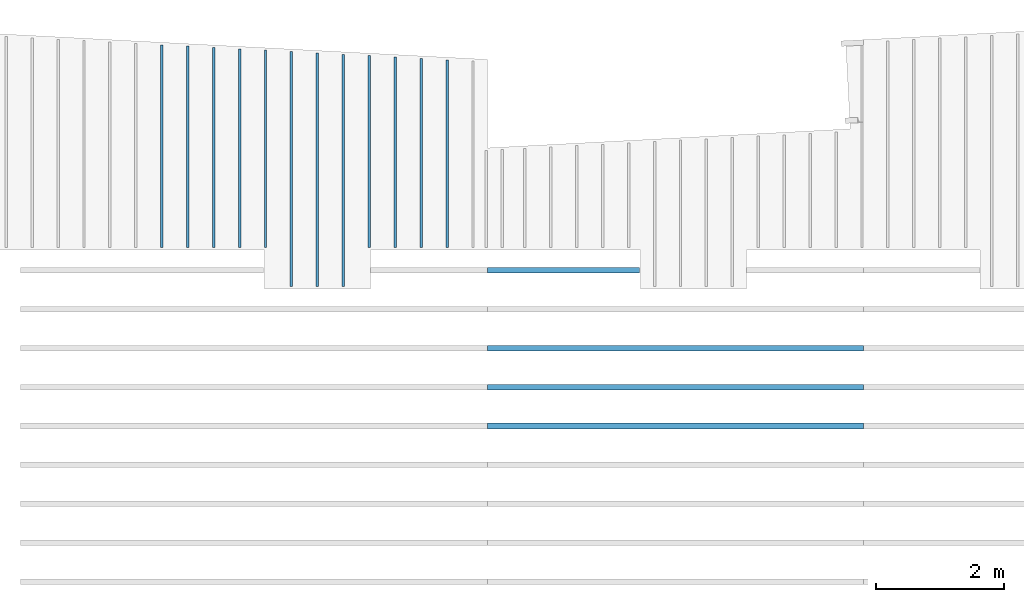
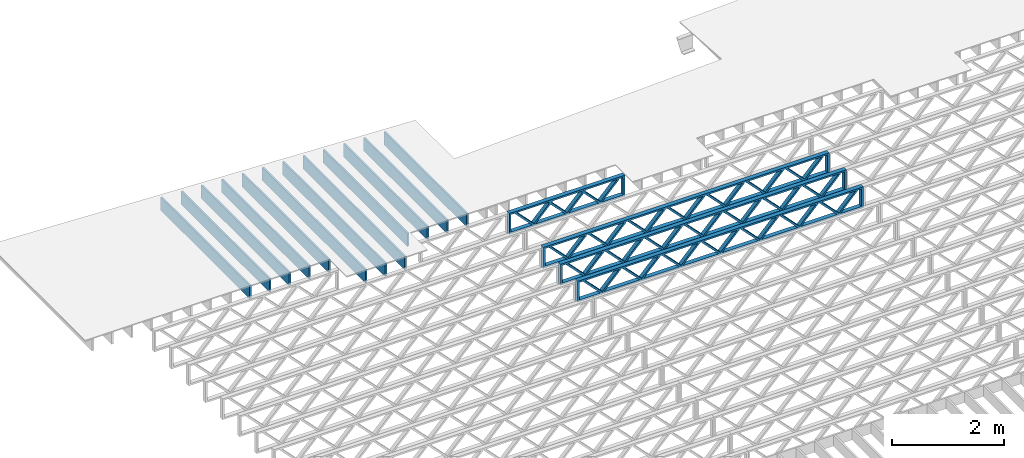
# One storey, part 4 of 13: 16 beams, 2 elements without a shape of their own.
"""IFC4 building model written with IfcOpenShell, lengths in feet."""

from ifc_helpers import new_model, entity, si_unit, converted_unit, derived_unit, direction, frame, frame_2d, origin, origin_2d_with_axis, place, context, subcontext, project, spatial, rectangle, extrude, source, transform, mapped, material, material_profile, profile_set, profile_usage, type_object, type_shapes, element, aggregate, save


model = new_model("IFC4")

# Units and contexts
model_context_1 = context("Model", 3, precision=0.0001, world=origin(), true_north=direction((6.12303176911189e-17, 1.0)))
model_context_2 = context("Model", 3, precision=0.0001, world=origin(), true_north=direction((6.12303176911189e-17, 1.0)))
body_context = subcontext(model_context_2, "Body", "Model", "MODEL_VIEW")
ifc_project = project(units=[converted_unit("LENGTHUNIT", "FOOT", entity("IfcRatioMeasure", 0.3048), si_unit("LENGTHUNIT", "METRE"), dimensions=[1, 0, 0, 0, 0, 0, 0]), converted_unit("AREAUNIT", "SQUARE FOOT", entity("IfcRatioMeasure", 0.09290304), si_unit("AREAUNIT", "SQUARE_METRE"), dimensions=[2, 0, 0, 0, 0, 0, 0]), converted_unit("VOLUMEUNIT", "CUBIC FOOT", entity("IfcRatioMeasure", 0.028316846592), si_unit("VOLUMEUNIT", "CUBIC_METRE"), dimensions=[3, 0, 0, 0, 0, 0, 0]), converted_unit("PLANEANGLEUNIT", "DEGREE", entity("IfcRatioMeasure", 0.0174532925199433), si_unit("PLANEANGLEUNIT", "RADIAN"), dimensions=[0, 0, 0, 0, 0, 0, 0]), si_unit("MASSUNIT", "GRAM", prefix="KILO"), derived_unit("MASSDENSITYUNIT", [(si_unit("MASSUNIT", "GRAM", prefix="KILO"), 1), (si_unit("LENGTHUNIT", "METRE"), -3)]), derived_unit("MOMENTOFINERTIAUNIT", [(si_unit("LENGTHUNIT", "METRE"), 4)]), si_unit("TIMEUNIT", "SECOND"), si_unit("FREQUENCYUNIT", "HERTZ"), si_unit("THERMODYNAMICTEMPERATUREUNIT", "DEGREE_CELSIUS"), derived_unit("THERMALTRANSMITTANCEUNIT", [(si_unit("MASSUNIT", "GRAM", prefix="KILO"), 1), (si_unit("THERMODYNAMICTEMPERATUREUNIT", "KELVIN"), -1), (si_unit("TIMEUNIT", "SECOND"), -3)]), derived_unit("VOLUMETRICFLOWRATEUNIT", [(si_unit("LENGTHUNIT", "METRE"), 3), (si_unit("TIMEUNIT", "SECOND"), -1)]), si_unit("ELECTRICCURRENTUNIT", "AMPERE"), si_unit("ELECTRICVOLTAGEUNIT", "VOLT"), si_unit("POWERUNIT", "WATT"), si_unit("FORCEUNIT", "NEWTON"), si_unit("ILLUMINANCEUNIT", "LUX"), si_unit("LUMINOUSFLUXUNIT", "LUMEN"), si_unit("LUMINOUSINTENSITYUNIT", "CANDELA"), derived_unit("USERDEFINED", [(si_unit("MASSUNIT", "GRAM", prefix="KILO"), -1), (si_unit("LENGTHUNIT", "METRE"), -2), (si_unit("TIMEUNIT", "SECOND"), 3), (si_unit("LUMINOUSFLUXUNIT", "LUMEN"), 1)]), derived_unit("LINEARVELOCITYUNIT", [(si_unit("LENGTHUNIT", "METRE"), 1), (si_unit("TIMEUNIT", "SECOND"), -1)]), si_unit("PRESSUREUNIT", "PASCAL"), derived_unit("USERDEFINED", [(si_unit("LENGTHUNIT", "METRE"), -2), (si_unit("MASSUNIT", "GRAM", prefix="KILO"), 1), (si_unit("TIMEUNIT", "SECOND"), -2)]), derived_unit("LINEARFORCEUNIT", [(si_unit("MASSUNIT", "GRAM", prefix="KILO"), 1), (si_unit("LENGTHUNIT", "METRE"), 1), (si_unit("TIMEUNIT", "SECOND"), -2), (si_unit("LENGTHUNIT", "METRE"), -1)]), derived_unit("PLANARFORCEUNIT", [(si_unit("MASSUNIT", "GRAM", prefix="KILO"), 1), (si_unit("LENGTHUNIT", "METRE"), 1), (si_unit("TIMEUNIT", "SECOND"), -2), (si_unit("LENGTHUNIT", "METRE"), -2)])], contexts=[model_context_1])

# Site, building, storey
site_placement = place(None, origin())
site = spatial("IfcSite", under=ifc_project, at=site_placement, CompositionType="ELEMENT")
building_placement = place(site_placement, origin())
building = spatial("IfcBuilding", under=site, at=building_placement, CompositionType="ELEMENT")
storey_placement = place(building_placement, frame((0.0, 0.0, 21.46875)))
storey = spatial("IfcBuildingStorey", under=building, at=storey_placement, Name="3RD FLOOR", CompositionType="ELEMENT", Elevation=21.46875)

# Assembly, beams
assembly_1_placement = place(storey_placement, origin())
assembly_1 = element("IfcElementAssembly", 1, at=assembly_1_placement, inside=storey, Name="Structural Beam System:Structural Framing System", ObjectType="Structural Beam System:Structural Framing System", AssemblyPlace="NOTDEFINED", PredefinedType="BEAM_GRID")
ifc_material_1 = material(Name="WOOD TRUSS", Category="Materials")
ifc_material_profile_1 = material_profile(ifc_material_1, rectangle(XDim=1.73473973950632, YDim=0.125, at=frame_2d((-1.11022302462516e-16, 8.32667268468867e-17), x_axis=(1.0, 0.0))))
ifc_material_profile_2 = material_profile(ifc_material_1, rectangle(XDim=1.73473973950633, YDim=0.125, at=frame_2d((-1.11022302462516e-16, 8.32667268468867e-17), x_axis=(1.0, 0.0))))
ifc_material_profile_3 = material_profile(ifc_material_1, rectangle(XDim=1.73473973950632, YDim=0.125, at=frame_2d((-5.55111512312578e-17, 1.38777878078145e-16), x_axis=(1.0, 0.0))))
ifc_material_profile_4 = material_profile(ifc_material_1, rectangle(XDim=1.73473973950633, YDim=0.125, at=frame_2d((-1.11022302462516e-16, 8.32667268468867e-17), x_axis=(1.0, 0.0))))
ifc_material_profile_5 = material_profile(ifc_material_1, rectangle(XDim=1.73473973950632, YDim=0.125, at=frame_2d((-1.11022302462516e-16, 8.32667268468867e-17), x_axis=(1.0, 0.0))))
ifc_material_profile_6 = material_profile(ifc_material_1, rectangle(XDim=1.73473973950633, YDim=0.125, at=frame_2d((-2.77555756156289e-16, 3.05311331771918e-16), x_axis=(1.0, 0.0))))
ifc_material_profile_7 = material_profile(ifc_material_1, rectangle(XDim=1.73473973950632, YDim=0.124999999999999, at=frame_2d((-3.88578058618805e-16, -2.4980018054066e-16), x_axis=(1.0, 0.0))))
ifc_material_profile_8 = material_profile(ifc_material_1, rectangle(XDim=1.73473973950633, YDim=0.125, at=frame_2d((2.77555756156289e-16, -3.05311331771918e-16), x_axis=(1.0, 0.0))))
ifc_material_profile_9 = material_profile(ifc_material_1, rectangle(XDim=1.73473973950632, YDim=0.124999999999999, at=frame_2d((-1.11022302462516e-16, 8.32667268468867e-17), x_axis=(1.0, 0.0))))
ifc_material_profile_10 = material_profile(ifc_material_1, rectangle(XDim=1.73473973950633, YDim=0.125, at=origin_2d_with_axis()))
ifc_material_profile_11 = material_profile(ifc_material_1, rectangle(XDim=0.124999999999982, YDim=0.291666666666668, at=origin_2d_with_axis()))
ifc_material_profile_12 = material_profile(ifc_material_1, rectangle(XDim=0.124999999999932, YDim=0.291666666666664, at=origin_2d_with_axis()))
ifc_material_profile_13 = material_profile(ifc_material_1, rectangle(XDim=1.25000000000002, YDim=0.29166666666667, at=origin_2d_with_axis()))
ifc_material_profile_14 = material_profile(ifc_material_1, rectangle(XDim=1.25000000000004, YDim=0.291666666666667, at=origin_2d_with_axis()))
ifc_profile_set_1 = profile_set([ifc_material_profile_1, ifc_material_profile_2, ifc_material_profile_3, ifc_material_profile_4, ifc_material_profile_5, ifc_material_profile_6, ifc_material_profile_7, ifc_material_profile_8, ifc_material_profile_9, ifc_material_profile_10, ifc_material_profile_11, ifc_material_profile_12, ifc_material_profile_13, ifc_material_profile_14])
ifc_profile_usage_1 = profile_usage(ifc_profile_set_1, cardinal=8)
beam_type_1 = type_object("IfcBeamType", PredefinedType="BEAM", material=ifc_profile_set_1)
shared_shape_1 = source(origin(), body_context, "Body", "SweptSolid", [
    extrude(rectangle(XDim=1.73473973950632, YDim=0.124999999999999, at=frame_2d((5.55111512312578e-16, 7.21644966006352e-16), x_axis=(1.0, 0.0))), frame((5.95847627016997, -0.145833333333334, 0.0), z_axis=(0.0, 1.0, 0.0), x_axis=(0.693383046997606, 0.0, 0.720569184836762)), (0.0, 0.0, 1.0), 0.291666666666667),
    extrude(rectangle(XDim=1.73473973950633, YDim=0.125, at=origin_2d_with_axis()), frame((4.7081903964967, -0.145833333333334, 0.0), z_axis=(0.0, 1.0, 0.0), x_axis=(0.69338304699761, 0.0, -0.720569184836758)), (0.0, 0.0, 1.0), 0.291666666666666),
    extrude(rectangle(XDim=1.73473973950632, YDim=0.125, at=frame_2d((2.22044604925031e-16, 3.88578058618805e-16), x_axis=(1.0, 0.0))), frame((3.29180960350347, -0.145833333333334, 0.0), z_axis=(0.0, 1.0, 0.0), x_axis=(0.693383046997606, 0.0, 0.720569184836762)), (0.0, 0.0, 1.0), 0.291666666666667),
    extrude(rectangle(XDim=1.73473973950633, YDim=0.125, at=frame_2d((1.11022302462516e-16, -8.32667268468867e-17), x_axis=(1.0, 0.0))), frame((2.0415237298302, -0.145833333333334, 0.0), z_axis=(0.0, 1.0, 0.0), x_axis=(0.69338304699761, 0.0, -0.720569184836758)), (0.0, 0.0, 1.0), 0.291666666666667),
    extrude(rectangle(XDim=1.73473973950632, YDim=0.125, at=frame_2d((-5.55111512312578e-17, 1.38777878078145e-16), x_axis=(1.0, 0.0))), frame((0.625142936836964, -0.145833333333334, 0.0), z_axis=(0.0, 1.0, 0.0), x_axis=(0.693383046997606, 0.0, 0.720569184836762)), (0.0, 0.0, 1.0), 0.291666666666667),
    extrude(rectangle(XDim=1.73473973950633, YDim=0.125, at=frame_2d((-1.11022302462516e-16, 8.32667268468867e-17), x_axis=(1.0, 0.0))), frame((-0.625142936836306, -0.145833333333334, 0.0), z_axis=(0.0, 1.0, 0.0), x_axis=(0.69338304699761, 0.0, -0.720569184836758)), (0.0, 0.0, 1.0), 0.291666666666667),
    extrude(rectangle(XDim=1.73473973950632, YDim=0.125, at=frame_2d((-1.11022302462516e-16, 8.32667268468867e-17), x_axis=(1.0, 0.0))), frame((-2.04152372982954, -0.145833333333334, 0.0), z_axis=(0.0, 1.0, 0.0), x_axis=(0.693383046997606, 0.0, 0.720569184836762)), (0.0, 0.0, 1.0), 0.291666666666667),
    extrude(rectangle(XDim=1.73473973950633, YDim=0.125, at=origin_2d_with_axis()), frame((-3.29180960350281, -0.145833333333334, 0.0), z_axis=(0.0, 1.0, 0.0), x_axis=(0.69338304699761, 0.0, -0.720569184836758)), (0.0, 0.0, 1.0), 0.291666666666667),
    extrude(rectangle(XDim=1.73473973950632, YDim=0.124999999999999, at=frame_2d((-1.11022302462516e-16, 8.32667268468867e-17), x_axis=(1.0, 0.0))), frame((-4.70819039649604, -0.145833333333334, 0.0), z_axis=(0.0, 1.0, 0.0), x_axis=(0.693383046997606, 0.0, 0.720569184836762)), (0.0, 0.0, 1.0), 0.291666666666667),
    extrude(rectangle(XDim=1.73473973950633, YDim=0.125, at=frame_2d((-5.55111512312578e-16, 6.38378239159465e-16), x_axis=(1.0, 0.0))), frame((-5.95847627016931, -0.145833333333334, 0.0), z_axis=(0.0, 1.0, 0.0), x_axis=(0.69338304699761, 0.0, -0.720569184836758)), (0.0, 0.0, 1.0), 0.291666666666666),
    extrude(rectangle(XDim=1.73473973950632, YDim=0.125, at=frame_2d((-7.21644966006352e-16, -5.82867087928207e-16), x_axis=(1.0, 0.0))), frame((8.62514293683647, -0.145833333333334, 0.0), z_axis=(0.0, 1.0, 0.0), x_axis=(0.693383046997607, 0.0, 0.720569184836761)), (0.0, 0.0, 1.0), 0.291666666666667),
    extrude(rectangle(XDim=1.73473973950633, YDim=0.125, at=origin_2d_with_axis()), frame((7.3748570631632, -0.145833333333334, 0.0), z_axis=(0.0, 1.0, 0.0), x_axis=(0.69338304699761, 0.0, -0.720569184836758)), (0.0, 0.0, 1.0), 0.291666666666666),
    extrude(rectangle(XDim=1.73473973950632, YDim=0.124999999999999, at=frame_2d((-1.11022302462516e-16, 8.32667268468867e-17), x_axis=(1.0, 0.0))), frame((-7.37485706316255, -0.145833333333334, 0.0), z_axis=(0.0, 1.0, 0.0), x_axis=(0.693383046997606, 0.0, 0.720569184836762)), (0.0, 0.0, 1.0), 0.291666666666667),
    extrude(rectangle(XDim=1.73473973950633, YDim=0.125, at=origin_2d_with_axis()), frame((-8.62514293683582, -0.145833333333334, 0.0), z_axis=(0.0, 1.0, 0.0), x_axis=(0.69338304699761, 0.0, -0.720569184836758)), (0.0, 0.0, 1.0), 0.291666666666666),
    extrude(rectangle(XDim=0.124999999999982, YDim=0.291666666666668, at=origin_2d_with_axis()), frame((-9.66666666666609, 0.0, 0.687500000000054), z_axis=(1.0, 0.0, 0.0), x_axis=(0.0, 0.0, -1.0)), (0.0, 0.0, 1.0), 19.3333333333322),
    extrude(rectangle(XDim=0.124999999999932, YDim=0.291666666666664, at=origin_2d_with_axis()), frame((-9.66666666666588, 0.0, -0.687499999999984), z_axis=(1.0, 0.0, 0.0), x_axis=(0.0, 0.0, -1.0)), (0.0, 0.0, 1.0), 19.333333333332),
    extrude(rectangle(XDim=1.25000000000002, YDim=0.29166666666667, at=origin_2d_with_axis()), frame((9.54166666666607, 0.0, 0.0), z_axis=(1.0, 0.0, 0.0), x_axis=(0.0, 0.0, -1.0)), (0.0, 0.0, 1.0), 0.12500000000002),
    extrude(rectangle(XDim=1.25000000000004, YDim=0.291666666666667, at=origin_2d_with_axis()), frame((-9.66666666666609, 0.0, 0.0), z_axis=(1.0, 0.0, 0.0), x_axis=(0.0, 0.0, -1.0)), (0.0, 0.0, 1.0), 0.125000000000023),
])
type_shapes(beam_type_1, [shared_shape_1])
beam_1_placement = place(assembly_1_placement, frame((-232.071493788724, 953.861934882651, -0.947916666666661)))
beam_1 = element("IfcBeam", 2, at=beam_1_placement, type_object=beam_type_1, material=ifc_profile_usage_1, PredefinedType="BEAM", context=body_context, shape_type="MappedRepresentation", body=[
    mapped(shared_shape_1, transform((0.0, 0.0, 0.0), scale=1.0)),
])
ifc_profile_usage_2 = profile_usage(ifc_profile_set_1, cardinal=8)
beam_2_placement = place(assembly_1_placement, frame((-232.071493788724, 951.861934882651, -0.947916666666661)))
beam_2 = element("IfcBeam", 3, at=beam_2_placement, type_object=beam_type_1, material=ifc_profile_usage_2, PredefinedType="BEAM", context=body_context, shape_type="MappedRepresentation", body=[
    mapped(shared_shape_1, transform((0.0, 0.0, 0.0), scale=1.0)),
])
ifc_profile_usage_3 = profile_usage(ifc_profile_set_1, cardinal=8)
beam_3_placement = place(assembly_1_placement, frame((-232.071493788724, 949.861934882651, -0.947916666666661)))
beam_3 = element("IfcBeam", 4, at=beam_3_placement, type_object=beam_type_1, material=ifc_profile_usage_3, PredefinedType="BEAM", context=body_context, shape_type="MappedRepresentation", body=[
    mapped(shared_shape_1, transform((0.0, 0.0, 0.0), scale=1.0)),
])
ifc_profile_usage_4 = profile_usage(ifc_profile_set_1, cardinal=8)
beam_type_2 = type_object("IfcBeamType", PredefinedType="BEAM", material=ifc_profile_set_1)
shared_shape_2 = source(origin(), body_context, "Body", "SweptSolid", [
    extrude(rectangle(XDim=1.73473973950632, YDim=0.125, at=frame_2d((-5.55111512312578e-17, 1.38777878078145e-16), x_axis=(1.0, 0.0))), frame((0.625142936836962, -0.145833333333334, 0.0), z_axis=(0.0, 1.0, 0.0), x_axis=(0.693383046997606, 0.0, 0.720569184836762)), (0.0, 0.0, 1.0), 0.291666666666667),
    extrude(rectangle(XDim=1.73473973950633, YDim=0.125, at=frame_2d((-1.11022302462516e-16, 8.32667268468867e-17), x_axis=(1.0, 0.0))), frame((-0.625142936836309, -0.145833333333334, 0.0), z_axis=(0.0, 1.0, 0.0), x_axis=(0.69338304699761, 0.0, -0.720569184836758)), (0.0, 0.0, 1.0), 0.291666666666667),
    extrude(rectangle(XDim=1.73473973950632, YDim=0.125, at=frame_2d((-1.11022302462516e-16, 8.32667268468867e-17), x_axis=(1.0, 0.0))), frame((2.87514283803796, -0.145833333333334, 0.0), z_axis=(0.0, 1.0, 0.0), x_axis=(0.693383046997606, 0.0, 0.720569184836762)), (0.0, 0.0, 1.0), 0.291666666666667),
    extrude(rectangle(XDim=1.73473973950633, YDim=0.125, at=frame_2d((-1.11022302462516e-16, 8.32667268468867e-17), x_axis=(1.0, 0.0))), frame((1.62485696436469, -0.145833333333334, 0.0), z_axis=(0.0, 1.0, 0.0), x_axis=(0.69338304699761, 0.0, -0.720569184836758)), (0.0, 0.0, 1.0), 0.291666666666667),
    extrude(rectangle(XDim=1.73473973950632, YDim=0.125, at=frame_2d((-1.11022302462516e-16, 8.32667268468867e-17), x_axis=(1.0, 0.0))), frame((-1.62485696436403, -0.145833333333334, 0.0), z_axis=(0.0, 1.0, 0.0), x_axis=(0.693383046997606, 0.0, 0.720569184836762)), (0.0, 0.0, 1.0), 0.291666666666667),
    extrude(rectangle(XDim=1.73473973950633, YDim=0.125, at=origin_2d_with_axis()), frame((-2.87514283803731, -0.145833333333334, 0.0), z_axis=(0.0, 1.0, 0.0), x_axis=(0.69338304699761, 0.0, -0.720569184836758)), (0.0, 0.0, 1.0), 0.291666666666667),
    extrude(rectangle(XDim=0.124999999999982, YDim=0.291666666666668, at=origin_2d_with_axis()), frame((-3.91666656786758, 0.0, 0.687500000000054), z_axis=(1.0, 0.0, 0.0), x_axis=(0.0, 0.0, -1.0)), (0.0, 0.0, 1.0), 7.83333313573516),
    extrude(rectangle(XDim=0.124999999999932, YDim=0.291666666666664, at=origin_2d_with_axis()), frame((-3.91666656786737, 0.0, -0.687499999999984), z_axis=(1.0, 0.0, 0.0), x_axis=(0.0, 0.0, -1.0)), (0.0, 0.0, 1.0), 7.83333313573495),
    extrude(rectangle(XDim=1.25000000000002, YDim=0.29166666666667, at=origin_2d_with_axis()), frame((3.79166656786756, 0.0, 0.0), z_axis=(1.0, 0.0, 0.0), x_axis=(0.0, 0.0, -1.0)), (0.0, 0.0, 1.0), 0.12500000000002),
    extrude(rectangle(XDim=1.25000000000004, YDim=0.291666666666667, at=origin_2d_with_axis()), frame((-3.91666656786758, 0.0, 0.0), z_axis=(1.0, 0.0, 0.0), x_axis=(0.0, 0.0, -1.0)), (0.0, 0.0, 1.0), 0.125000000000023),
])
type_shapes(beam_type_2, [shared_shape_2])
beam_4_placement = place(assembly_1_placement, frame((-237.821493887522, 957.861934882651, -0.947916666666661)))
beam_4 = element("IfcBeam", 5, at=beam_4_placement, type_object=beam_type_2, material=ifc_profile_usage_4, PredefinedType="BEAM", context=body_context, shape_type="MappedRepresentation", body=[
    mapped(shared_shape_2, transform((0.0, 0.0, 0.0), scale=1.0)),
])
aggregate(assembly_1, [beam_1, beam_2, beam_3, beam_4])

assembly_2_placement = place(storey_placement, origin())
assembly_2 = element("IfcElementAssembly", 6, at=assembly_2_placement, inside=storey, Name="Structural Beam System:Structural Framing System", ObjectType="Structural Beam System:Structural Framing System", AssemblyPlace="NOTDEFINED", PredefinedType="BEAM_GRID")
ifc_material_2 = material(Category="Materials")
ifc_material_profile_15 = material_profile(ifc_material_2, rectangle(XDim=0.9375, YDim=0.125000000000011, at=origin_2d_with_axis()))
ifc_profile_set_2 = profile_set([ifc_material_profile_15])
ifc_profile_usage_5 = profile_usage(ifc_profile_set_2, cardinal=8)
beam_type_3 = type_object("IfcBeamType", PredefinedType="BEAM", material=ifc_profile_set_2)
shared_shape_3 = source(origin(), body_context, "Body", "SweptSolid", [
    extrude(rectangle(XDim=0.9375, YDim=0.125000000000011, at=origin_2d_with_axis()), frame((-4.86611712765506, 0.0, 0.0), z_axis=(1.0, 0.0, 0.0), x_axis=(0.0, 0.0, -1.0)), (0.0, 0.0, 1.0), 9.73223425531012),
])
type_shapes(beam_type_3, [shared_shape_3])
beam_5_placement = place(assembly_2_placement, frame((-245.144289395965, 963.895636651089, -0.729166666666714), z_axis=(0.0, 0.0, 1.0), x_axis=(0.0, 1.0, 0.0)))
beam_5 = element("IfcBeam", 7, at=beam_5_placement, type_object=beam_type_3, material=ifc_profile_usage_5, PredefinedType="BEAM", context=body_context, shape_type="MappedRepresentation", body=[
    mapped(shared_shape_3, transform((0.0, 0.0, 0.0), scale=1.0)),
])
ifc_profile_usage_6 = profile_usage(ifc_profile_set_2, cardinal=8)
beam_type_4 = type_object("IfcBeamType", PredefinedType="BEAM", material=ifc_profile_set_2)
shared_shape_4 = source(origin(), body_context, "Body", "SweptSolid", [
    extrude(rectangle(XDim=0.9375, YDim=0.125000000000011, at=origin_2d_with_axis()), frame((-4.93599383169669, 0.0, 0.0), z_axis=(1.0, 0.0, 0.0), x_axis=(0.0, 0.0, -1.0)), (0.0, 0.0, 1.0), 9.87198766339338),
])
type_shapes(beam_type_4, [shared_shape_4])
beam_6_placement = place(assembly_2_placement, frame((-247.810956062631, 963.965514025136, -0.729166666666714), z_axis=(0.0, 0.0, 1.0), x_axis=(0.0, 1.0, 0.0)))
beam_6 = element("IfcBeam", 8, at=beam_6_placement, type_object=beam_type_4, material=ifc_profile_usage_6, PredefinedType="BEAM", context=body_context, shape_type="MappedRepresentation", body=[
    mapped(shared_shape_4, transform((0.0, 0.0, 0.0), scale=1.0)),
])
ifc_profile_usage_7 = profile_usage(ifc_profile_set_2, cardinal=8)
beam_type_5 = type_object("IfcBeamType", PredefinedType="BEAM", material=ifc_profile_set_2)
shared_shape_5 = source(origin(), body_context, "Body", "SweptSolid", [
    extrude(rectangle(XDim=0.9375, YDim=0.125000000000011, at=origin_2d_with_axis()), frame((-5.97093433748853, 0.0, 0.0), z_axis=(1.0, 0.0, 0.0), x_axis=(0.0, 0.0, -1.0)), (0.0, 0.0, 1.0), 11.9418686749771),
])
type_shapes(beam_type_5, [shared_shape_5])
beam_7_placement = place(assembly_2_placement, frame((-249.144289395965, 963.000450558388, -0.729166666666714), z_axis=(0.0, 0.0, 1.0), x_axis=(0.0, 1.0, 0.0)))
beam_7 = element("IfcBeam", 9, at=beam_7_placement, type_object=beam_type_5, material=ifc_profile_usage_7, PredefinedType="BEAM", context=body_context, shape_type="MappedRepresentation", body=[
    mapped(shared_shape_5, transform((0.0, 0.0, 0.0), scale=1.0)),
])
ifc_profile_usage_8 = profile_usage(ifc_profile_set_2, cardinal=8)
beam_type_6 = type_object("IfcBeamType", PredefinedType="BEAM", material=ifc_profile_set_2)
shared_shape_6 = source(origin(), body_context, "Body", "SweptSolid", [
    extrude(rectangle(XDim=0.9375, YDim=0.125000000000011, at=origin_2d_with_axis()), frame((-6.00587285701056, 0.0, 0.0), z_axis=(1.0, 0.0, 0.0), x_axis=(0.0, 0.0, -1.0)), (0.0, 0.0, 1.0), 12.0117457140211),
])
type_shapes(beam_type_6, [shared_shape_6])
beam_8_placement = place(assembly_2_placement, frame((-250.477622729298, 963.03538907791, -0.729166666666714), z_axis=(0.0, 0.0, 1.0), x_axis=(0.0, 1.0, 0.0)))
beam_8 = element("IfcBeam", 10, at=beam_8_placement, type_object=beam_type_6, material=ifc_profile_usage_8, PredefinedType="BEAM", context=body_context, shape_type="MappedRepresentation", body=[
    mapped(shared_shape_6, transform((0.0, 0.0, 0.0), scale=1.0)),
])
ifc_profile_usage_9 = profile_usage(ifc_profile_set_2, cardinal=8)
beam_type_7 = type_object("IfcBeamType", PredefinedType="BEAM", material=ifc_profile_set_2)
shared_shape_7 = source(origin(), body_context, "Body", "SweptSolid", [
    extrude(rectangle(XDim=0.9375, YDim=0.125000000000011, at=origin_2d_with_axis()), frame((-6.04081137653259, 0.0, 0.0), z_axis=(1.0, 0.0, 0.0), x_axis=(0.0, 0.0, -1.0)), (0.0, 0.0, 1.0), 12.0816227530652),
])
type_shapes(beam_type_7, [shared_shape_7])
beam_9_placement = place(assembly_2_placement, frame((-251.810956062631, 963.070327597432, -0.729166666666714), z_axis=(0.0, 0.0, 1.0), x_axis=(0.0, 1.0, 0.0)))
beam_9 = element("IfcBeam", 11, at=beam_9_placement, type_object=beam_type_7, material=ifc_profile_usage_9, PredefinedType="BEAM", context=body_context, shape_type="MappedRepresentation", body=[
    mapped(shared_shape_7, transform((0.0, 0.0, 0.0), scale=1.0)),
])
ifc_profile_usage_10 = profile_usage(ifc_profile_set_2, cardinal=8)
beam_type_8 = type_object("IfcBeamType", PredefinedType="BEAM", material=ifc_profile_set_2)
shared_shape_8 = source(origin(), body_context, "Body", "SweptSolid", [
    extrude(rectangle(XDim=0.9375, YDim=0.125000000000011, at=origin_2d_with_axis()), frame((-5.11114599123374, 0.0, 0.0), z_axis=(1.0, 0.0, 0.0), x_axis=(0.0, 0.0, -1.0)), (0.0, 0.0, 1.0), 10.2222919824675),
])
type_shapes(beam_type_8, [shared_shape_8])
beam_10_placement = place(assembly_2_placement, frame((-254.477622719368, 964.139747060298, -0.729166666666714), z_axis=(0.0, 0.0, 1.0), x_axis=(0.0, 1.0, 0.0)))
beam_10 = element("IfcBeam", 12, at=beam_10_placement, type_object=beam_type_8, material=ifc_profile_usage_10, PredefinedType="BEAM", context=body_context, shape_type="MappedRepresentation", body=[
    mapped(shared_shape_8, transform((0.0, 0.0, 0.0), scale=1.0)),
])
ifc_profile_usage_11 = profile_usage(ifc_profile_set_2, cardinal=8)
beam_type_9 = type_object("IfcBeamType", PredefinedType="BEAM", material=ifc_profile_set_2)
shared_shape_9 = source(origin(), body_context, "Body", "SweptSolid", [
    extrude(rectangle(XDim=0.9375, YDim=0.125000000000011, at=origin_2d_with_axis()), frame((-5.21596154979977, 0.0, 0.0), z_axis=(1.0, 0.0, 0.0), x_axis=(0.0, 0.0, -1.0)), (0.0, 0.0, 1.0), 10.4319230995995),
])
type_shapes(beam_type_9, [shared_shape_9])
beam_11_placement = place(assembly_2_placement, frame((-258.477622719368, 964.244562618864, -0.729166666666714), z_axis=(0.0, 0.0, 1.0), x_axis=(0.0, 1.0, 0.0)))
beam_11 = element("IfcBeam", 13, at=beam_11_placement, type_object=beam_type_9, material=ifc_profile_usage_11, PredefinedType="BEAM", context=body_context, shape_type="MappedRepresentation", body=[
    mapped(shared_shape_9, transform((0.0, 0.0, 0.0), scale=1.0)),
])
ifc_profile_usage_12 = profile_usage(ifc_profile_set_2, cardinal=8)
beam_type_10 = type_object("IfcBeamType", PredefinedType="BEAM", material=ifc_profile_set_2)
shared_shape_10 = source(origin(), body_context, "Body", "SweptSolid", [
    extrude(rectangle(XDim=0.9375, YDim=0.125000000000011, at=origin_2d_with_axis()), frame((-5.1810230302778, 0.0, 0.0), z_axis=(1.0, 0.0, 0.0), x_axis=(0.0, 0.0, -1.0)), (0.0, 0.0, 1.0), 10.3620460605556),
])
type_shapes(beam_type_10, [shared_shape_10])
beam_12_placement = place(assembly_2_placement, frame((-257.144289386034, 964.209624099342, -0.729166666666714), z_axis=(0.0, 0.0, 1.0), x_axis=(0.0, 1.0, 0.0)))
beam_12 = element("IfcBeam", 14, at=beam_12_placement, type_object=beam_type_10, material=ifc_profile_usage_12, PredefinedType="BEAM", context=body_context, shape_type="MappedRepresentation", body=[
    mapped(shared_shape_10, transform((0.0, 0.0, 0.0), scale=1.0)),
])
ifc_profile_usage_13 = profile_usage(ifc_profile_set_2, cardinal=8)
beam_type_11 = type_object("IfcBeamType", PredefinedType="BEAM", material=ifc_profile_set_2)
shared_shape_11 = source(origin(), body_context, "Body", "SweptSolid", [
    extrude(rectangle(XDim=0.9375, YDim=0.125000000000011, at=origin_2d_with_axis()), frame((-5.14608451075577, 0.0, 0.0), z_axis=(1.0, 0.0, 0.0), x_axis=(0.0, 0.0, -1.0)), (0.0, 0.0, 1.0), 10.2921690215115),
])
type_shapes(beam_type_11, [shared_shape_11])
beam_13_placement = place(assembly_2_placement, frame((-255.810956052701, 964.17468557982, -0.729166666666714), z_axis=(0.0, 0.0, 1.0), x_axis=(0.0, 1.0, 0.0)))
beam_13 = element("IfcBeam", 15, at=beam_13_placement, type_object=beam_type_11, material=ifc_profile_usage_13, PredefinedType="BEAM", context=body_context, shape_type="MappedRepresentation", body=[
    mapped(shared_shape_11, transform((0.0, 0.0, 0.0), scale=1.0)),
])
ifc_profile_usage_14 = profile_usage(ifc_profile_set_2, cardinal=8)
beam_type_12 = type_object("IfcBeamType", PredefinedType="BEAM", material=ifc_profile_set_2)
shared_shape_12 = source(origin(), body_context, "Body", "SweptSolid", [
    extrude(rectangle(XDim=0.9375, YDim=0.125000000000011, at=origin_2d_with_axis()), frame((-5.07620747171171, 0.0, 0.0), z_axis=(1.0, 0.0, 0.0), x_axis=(0.0, 0.0, -1.0)), (0.0, 0.0, 1.0), 10.1524149434234),
])
type_shapes(beam_type_12, [shared_shape_12])
beam_14_placement = place(assembly_2_placement, frame((-253.144289386034, 964.104808540776, -0.729166666666714), z_axis=(0.0, 0.0, 1.0), x_axis=(0.0, 1.0, 0.0)))
beam_14 = element("IfcBeam", 16, at=beam_14_placement, type_object=beam_type_12, material=ifc_profile_usage_14, PredefinedType="BEAM", context=body_context, shape_type="MappedRepresentation", body=[
    mapped(shared_shape_12, transform((0.0, 0.0, 0.0), scale=1.0)),
])
ifc_profile_usage_15 = profile_usage(ifc_profile_set_2, cardinal=8)
beam_type_13 = type_object("IfcBeamType", PredefinedType="BEAM", material=ifc_profile_set_2)
shared_shape_13 = source(origin(), body_context, "Body", "SweptSolid", [
    extrude(rectangle(XDim=0.9375, YDim=0.125000000000011, at=origin_2d_with_axis()), frame((-4.90105547967585, 0.0, 0.0), z_axis=(1.0, 0.0, 0.0), x_axis=(0.0, 0.0, -1.0)), (0.0, 0.0, 1.0), 9.80211095935169),
])
type_shapes(beam_type_13, [shared_shape_13])
beam_15_placement = place(assembly_2_placement, frame((-246.477622729298, 963.930575338113, -0.729166666666714), z_axis=(0.0, 0.0, 1.0), x_axis=(0.0, 1.0, 0.0)))
beam_15 = element("IfcBeam", 17, at=beam_15_placement, type_object=beam_type_13, material=ifc_profile_usage_15, PredefinedType="BEAM", context=body_context, shape_type="MappedRepresentation", body=[
    mapped(shared_shape_13, transform((0.0, 0.0, 0.0), scale=1.0)),
])
ifc_profile_usage_16 = profile_usage(ifc_profile_set_2, cardinal=8)
beam_type_14 = type_object("IfcBeamType", PredefinedType="BEAM", material=ifc_profile_set_2)
shared_shape_14 = source(origin(), body_context, "Body", "SweptSolid", [
    extrude(rectangle(XDim=0.9375, YDim=0.125000000000011, at=origin_2d_with_axis()), frame((-4.83117877563427, 0.0, 0.0), z_axis=(1.0, 0.0, 0.0), x_axis=(0.0, 0.0, -1.0)), (0.0, 0.0, 1.0), 9.66235755126854),
])
type_shapes(beam_type_14, [shared_shape_14])
beam_16_placement = place(assembly_2_placement, frame((-243.810956062631, 963.860697964066, -0.729166666666714), z_axis=(0.0, 0.0, 1.0), x_axis=(0.0, 1.0, 0.0)))
beam_16 = element("IfcBeam", 18, at=beam_16_placement, type_object=beam_type_14, material=ifc_profile_usage_16, PredefinedType="BEAM", context=body_context, shape_type="MappedRepresentation", body=[
    mapped(shared_shape_14, transform((0.0, 0.0, 0.0), scale=1.0)),
])
aggregate(assembly_2, [beam_5, beam_6, beam_7, beam_8, beam_9, beam_10, beam_11, beam_12, beam_13, beam_14, beam_15, beam_16])

save(model, "model.ifc")
